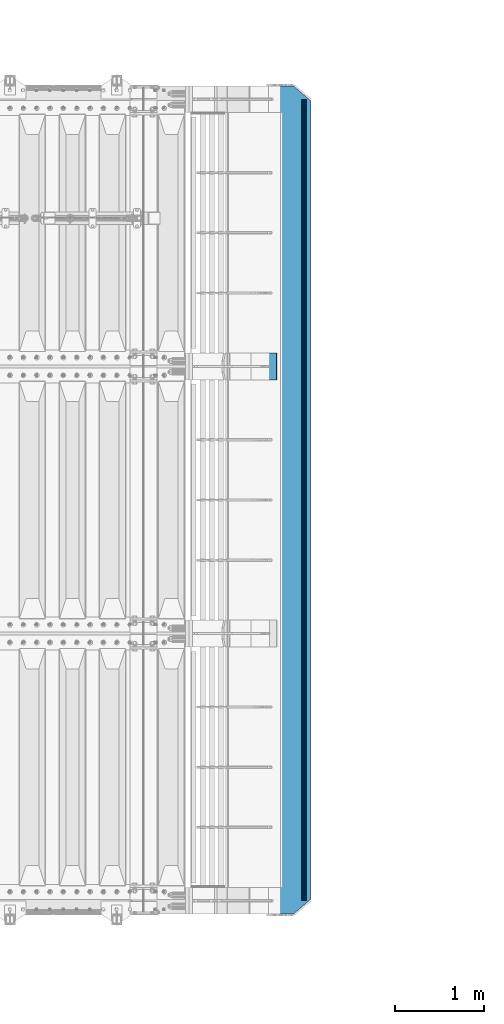
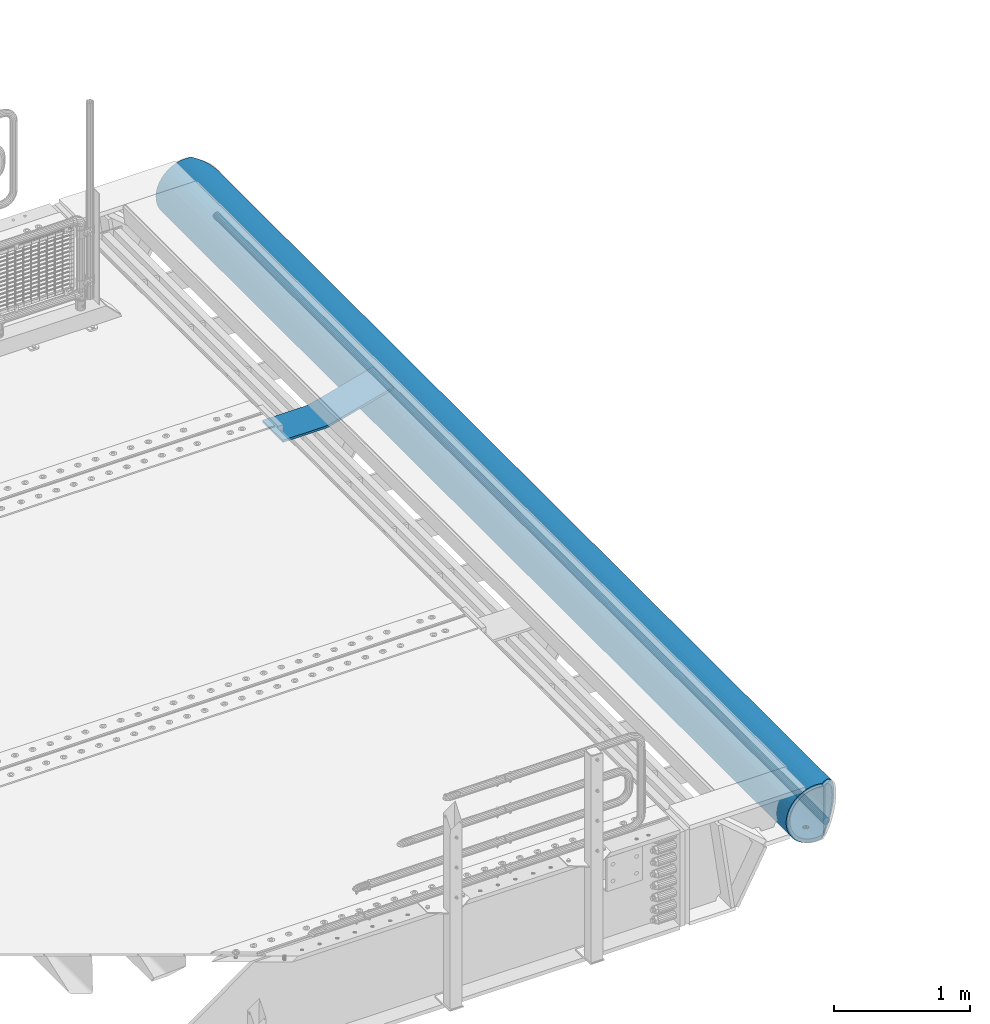
# One storey, part 144 of 270: 3 beams.
"""IFC2X3 building model written with IfcOpenShell, lengths in millimetres."""

from ifc_helpers import new_model, si_unit, frame, origin_with_axes, place, context, subcontext, project, spatial, faceted_brep, material, type_object, element, save


model = new_model("IFC2X3")

# Units and contexts
model_context = context("Model", 3, precision=1e-05, world=origin_with_axes())
body_context = subcontext(model_context, "Body", "Model", "MODEL_VIEW")
ifc_project = project(units=[si_unit("LENGTHUNIT", "METRE", prefix="MILLI"), si_unit("AREAUNIT", "SQUARE_METRE"), si_unit("VOLUMEUNIT", "CUBIC_METRE"), si_unit("MASSUNIT", "GRAM", prefix="KILO"), si_unit("TIMEUNIT", "SECOND"), si_unit("PLANEANGLEUNIT", "RADIAN"), si_unit("SOLIDANGLEUNIT", "STERADIAN"), si_unit("THERMODYNAMICTEMPERATUREUNIT", "DEGREE_CELSIUS"), si_unit("LUMINOUSINTENSITYUNIT", "LUMEN")], contexts=[model_context])

# Site, building, storey
site_placement = place(None, origin_with_axes())
site = spatial("IfcSite", under=ifc_project, at=site_placement, CompositionType="ELEMENT")
building_placement = place(site_placement, origin_with_axes())
building = spatial("IfcBuilding", under=site, at=building_placement, Name="Standard", CompositionType="ELEMENT")
storey_placement = place(building_placement, origin_with_axes())
storey = spatial("IfcBuildingStorey", under=building, at=storey_placement, Name="Undefined", CompositionType="ELEMENT", Elevation=0.0)

# Beams
ifc_material = material(Name="STEEL/S355N")
beam_type_1 = type_object("IfcBeamType", PredefinedType="NOTDEFINED")
beam_1_placement = place(storey_placement, frame((20469.9988298906, -18000.0, -169.999999999995), z_axis=(0.0, -1.0, 0.0), x_axis=(1.0, 0.0, 0.0)))
element("IfcBeam", 1, at=beam_1_placement, inside=storey, type_object=beam_type_1, material=ifc_material, context=body_context, shape_type="Brep", body=[
    faceted_brep([(0.0, 10.0, -150.0), (0.0, 10.0, 150.0), (356.495387467741, 10.0, 150.0), (356.495387467749, 9.99999999999901, -150.0), (0.0, -10.0, 150.0), (0.0, -10.0, -150.0), (356.495387467741, -10.0, -150.0), (356.495387467741, -10.0, 150.0), (382.770279632416, 11.7334369044542, 150.0), (382.770279632416, 11.7334369044542, -150.0), (385.397768848896, -8.09321940509935, -150.0), (385.397768848896, -8.09321940509935, 150.0), (413.799145684919, -2.40593045895554, -150.0), (413.799145684919, -2.40593045895554, 150.0), (408.589713119687, 16.9036995827646, 150.0), (408.589713119891, 16.9036995827009, -150.0), (939.000000000015, 160.0, 150.0), (939.000000000015, 160.0, -150.0), (944.209432565229, 140.69036995827, 150.0), (944.209432565229, 140.69036995827, -150.0)], [[[0, 1, 2, 3]], [[4, 5, 6, 7]], [[5, 4, 1, 0]], [[3, 2, 8, 9]], [[7, 6, 10, 11]], [[10, 12, 13, 11]], [[8, 14, 15, 9]], [[15, 14, 16, 17]], [[14, 8, 2, 1, 4, 7, 11, 13, 18, 16]], [[13, 12, 19, 18]], [[12, 10, 6, 5, 0, 3, 9, 15, 17, 19]], [[18, 19, 17, 16]]]),
])
beam_type_2 = type_object("IfcBeamType", PredefinedType="NOTDEFINED")
beam_2_placement = place(storey_placement, frame((21545.9988298906, -14850.0, -254.000000000001), z_axis=(0.0, 0.0, 1.0), x_axis=(0.0, -1.0, 0.0)))
element("IfcBeam", 2, at=beam_2_placement, inside=storey, type_object=beam_type_2, material=ifc_material, context=body_context, shape_type="Brep", body=[
    faceted_brep([(6132.32233047034, -17.6739734137809, -220.609028125962), (6132.32233047034, -17.6739734137809, -252.609028125962), (6126.90301168722, -9.56338969324497, -253.247344908112), (6126.90301168722, -9.56338969324497, -221.247344908112), (6140.43291419087, -23.0932921968997, -220.182518487904), (6140.43291419087, -23.0932921968997, -252.182518487904), (6150.0, -24.9963038841161, -220.032748220012), (6150.0, -24.9963038841161, -252.032748220013), (6159.56708580913, -23.0932921968997, -220.182518487904), (6159.56708580913, -23.0932921968997, -252.182518487904), (6167.67766952966, -17.6739734137809, -220.609028125962), (6167.67766952966, -17.6739734137809, -252.609028125962), (6173.09698831278, -9.56338969324497, -221.247344908112), (6173.09698831278, -9.56338969324497, -253.247344908112), (6175.0, 0.0, -222.0), (6175.0, 0.0, -254.0), (6173.09698831278, 9.57078192501285, -221.246763126855), (6173.09698831278, 9.57078192501285, -253.246763126855), (6167.67766952966, 17.6813656455488, -220.608446344705), (6167.67766952966, 17.6813656455488, -252.608446344705), (6159.56708580913, 23.1006844286676, -220.181936706647), (6159.56708580913, 23.1006844286676, -252.181936706647), (6150.0, 25.0036961158839, -220.032166438756), (6150.0, 25.0036961158839, -252.032166438756), (6140.43291419087, 23.1006844286676, -220.181936706647), (6140.43291419087, 23.1006844286676, -252.181936706647), (6132.32233047034, 17.6813656455488, -220.608446344705), (6132.32233047034, 17.6813656455488, -252.608446344705), (6126.90301168722, 9.57078192501285, -221.246763126855), (6126.90301168722, 9.57078192501285, -253.246763126855), (6125.0, 0.0, -222.0), (6125.0, 0.0, -254.0), (4632.32233047034, -17.6739734137773, -220.609028125962), (4632.32233047034, -17.6739734137773, -252.609028125962), (4626.90301168722, -9.56338969324133, -253.247344908112), (4626.90301168722, -9.56338969324133, -221.247344908113), (4640.43291419087, -23.0932921968961, -220.182518487904), (4640.43291419087, -23.0932921968961, -252.182518487904), (4650.0, -24.9963038841124, -220.032748220013), (4650.0, -24.9963038841124, -252.032748220013), (4659.56708580913, -23.0932921968961, -220.182518487904), (4659.56708580913, -23.0932921968961, -252.182518487904), (4667.67766952966, -17.6739734137773, -220.609028125962), (4667.67766952966, -17.6739734137773, -252.609028125962), (4673.09698831278, -9.56338969324133, -221.247344908113), (4673.09698831278, -9.56338969324133, -253.247344908112), (4675.0, 0.0, -222.0), (4675.0, 0.0, -254.0), (4673.09698831278, 9.57078192501649, -221.246763126855), (4673.09698831278, 9.57078192501649, -253.246763126855), (4667.67766952966, 17.6813656455524, -220.608446344705), (4667.67766952966, 17.6813656455524, -252.608446344705), (4659.56708580913, 23.1006844286712, -220.181936706647), (4659.56708580913, 23.1006844286712, -252.181936706646), (4650.0, 25.0036961158876, -220.032166438755), (4650.0, 25.0036961158876, -252.032166438755), (4640.43291419087, 23.1006844286712, -220.181936706647), (4640.43291419087, 23.1006844286712, -252.181936706646), (4632.32233047034, 17.6813656455524, -220.608446344705), (4632.32233047034, 17.6813656455524, -252.608446344705), (4626.90301168722, 9.57078192501649, -221.246763126855), (4626.90301168722, 9.57078192501649, -253.246763126855), (4625.0, 0.0, -222.0), (4625.0, 0.0, -254.0), (3132.32233047034, -17.6776695296612, -220.608737235334), (3132.32233047034, -17.6776695296612, -252.608737235334), (3126.90301168722, -9.56708580912527, -253.247054017484), (3126.90301168722, -9.56708580912527, -221.247054017484), (3140.43291419087, -23.09698831278, -220.182227597276), (3140.43291419087, -23.09698831278, -252.182227597276), (3150.0, -24.9999999999964, -220.032457329385), (3150.0, -24.9999999999964, -252.032457329385), (3159.56708580913, -23.09698831278, -220.182227597276), (3159.56708580913, -23.09698831278, -252.182227597276), (3167.67766952966, -17.6776695296612, -220.608737235334), (3167.67766952966, -17.6776695296612, -252.608737235334), (3173.09698831278, -9.56708580912527, -221.247054017484), (3173.09698831278, -9.56708580912527, -253.247054017484), (3175.0, 0.0, -222.0), (3175.0, 0.0, -254.0), (3173.09698831278, 9.56708580913255, -221.247054017483), (3173.09698831278, 9.56708580913255, -253.247054017483), (3167.67766952966, 17.6776695296685, -220.608737235333), (3167.67766952966, 17.6776695296685, -252.608737235333), (3159.56708580913, 23.0969883127873, -220.182227597275), (3159.56708580913, 23.0969883127873, -252.182227597275), (3150.0, 25.0000000000036, -220.032457329384), (3150.0, 25.0000000000036, -252.032457329383), (3140.43291419087, 23.0969883127873, -220.182227597275), (3140.43291419087, 23.0969883127873, -252.182227597275), (3132.32233047034, 17.6776695296685, -220.608737235333), (3132.32233047034, 17.6776695296685, -252.608737235333), (3126.90301168722, 9.56708580913255, -221.247054017483), (3126.90301168722, 9.56708580913255, -253.247054017483), (3125.0, 0.0, -222.0), (3125.0, 0.0, -254.0), (1632.32233047034, -17.6776695296612, -220.608737235334), (1632.32233047034, -17.6776695296612, -252.608737235334), (1626.90301168722, -9.56708580912527, -253.247054017484), (1626.90301168722, -9.56708580912527, -221.247054017484), (1640.43291419087, -23.09698831278, -220.182227597276), (1640.43291419087, -23.09698831278, -252.182227597275), (1650.0, -24.9999999999964, -220.032457329384), (1650.0, -24.9999999999964, -252.032457329384), (1659.56708580913, -23.09698831278, -220.182227597276), (1659.56708580913, -23.09698831278, -252.182227597275), (1667.67766952966, -17.6776695296612, -220.608737235334), (1667.67766952966, -17.6776695296612, -252.608737235334), (1673.09698831278, -9.56708580912527, -221.247054017484), (1673.09698831278, -9.56708580912527, -253.247054017484), (1675.0, 0.0, -222.0), (1675.0, 0.0, -254.0), (1673.09698831278, 9.56708580913255, -221.247054017483), (1673.09698831278, 9.56708580913255, -253.247054017483), (1667.67766952966, 17.6776695296685, -220.608737235333), (1667.67766952966, 17.6776695296685, -252.608737235333), (1659.56708580913, 23.0969883127873, -220.182227597275), (1659.56708580913, 23.0969883127873, -252.182227597275), (1650.0, 25.0000000000036, -220.032457329384), (1650.0, 25.0000000000036, -252.032457329384), (1640.43291419087, 23.0969883127873, -220.182227597275), (1640.43291419087, 23.0969883127873, -252.182227597275), (1632.32233047034, 17.6776695296685, -220.608737235333), (1632.32233047034, 17.6776695296685, -252.608737235333), (1626.90301168722, 9.56708580913255, -221.247054017483), (1626.90301168722, 9.56708580913255, -253.247054017483), (1625.0, 0.0, -222.0), (1625.0, 0.0, -254.0), (132.322330470337, -17.6776695296612, -220.608737235334), (132.322330470337, -17.6776695296612, -252.608737235334), (126.903011687218, -9.56708580912527, -253.247054017484), (126.903011687218, -9.56708580912527, -221.247054017484), (140.432914190873, -23.09698831278, -220.182227597276), (140.432914190873, -23.09698831278, -252.182227597276), (150.0, -24.9999999999964, -220.032457329385), (150.0, -24.9999999999964, -252.032457329384), (159.567085809127, -23.09698831278, -220.182227597276), (159.567085809127, -23.09698831278, -252.182227597276), (167.677669529663, -17.6776695296612, -220.608737235334), (167.677669529663, -17.6776695296612, -252.608737235334), (173.096988312782, -9.56708580912527, -221.247054017484), (173.096988312782, -9.56708580912527, -253.247054017484), (175.0, 0.0, -222.0), (175.0, 0.0, -254.0), (173.096988312782, 9.56708580913255, -221.247054017483), (173.096988312782, 9.56708580913255, -253.247054017484), (167.677669529663, 17.6776695296685, -220.608737235333), (167.677669529663, 17.6776695296685, -252.608737235333), (159.567085809127, 23.0969883127873, -220.182227597275), (159.567085809127, 23.0969883127873, -252.182227597275), (150.0, 25.0000000000036, -220.032457329384), (150.0, 25.0000000000036, -252.032457329384), (140.432914190873, 23.0969883127873, -220.182227597275), (140.432914190873, 23.0969883127873, -252.182227597275), (132.322330470337, 17.6776695296685, -220.608737235333), (132.322330470337, 17.6776695296685, -252.608737235333), (126.903011687218, 9.56708580913255, -221.247054017483), (126.903011687218, 9.56708580913255, -253.247054017484), (125.0, 0.0, -222.0), (125.0, 0.0, -254.0), (0.0, -34.7284512389306, -219.266811612121), (0.0, -68.6017727512371, -211.134546617524), (9300.0, -68.6017727512371, -211.134546617524), (9300.0, -34.7284512389306, -219.266811612121), (0.0, -100.785890942181, -197.803448369818), (9300.0, -100.785890942181, -197.803448369818), (0.0, -130.48832600893, -179.601772751238), (9300.0, -130.48832600893, -179.601772751238), (0.0, -156.977705423415, -156.977705423414), (9300.0, -156.977705423415, -156.977705423414), (0.0, -179.601772751237, -130.488326008929), (9300.0, -179.601772751237, -130.488326008929), (0.0, -197.803448369817, -100.785890942179), (9300.0, -197.803448369817, -100.785890942179), (0.0, -211.134546617523, -68.6017727512383), (9300.0, -211.134546617523, -68.6017727512383), (0.0, -219.26681161212, -34.7284512389313), (9300.0, -219.26681161212, -34.7284512389313), (0.0, -222.0, 0.0), (9300.0, -222.0, 0.0), (0.0, -219.26681161212, 34.7284512389313), (9300.0, -219.26681161212, 34.7284512389313), (0.0, -211.134546617523, 68.6017727512384), (9300.0, -211.134546617523, 68.6017727512384), (0.0, -197.803448369817, 100.785890942179), (9300.0, -197.803448369817, 100.785890942179), (0.0, -179.601772751237, 130.488326008929), (9300.0, -179.601772751237, 130.488326008929), (0.0, -156.977705423415, 156.977705423414), (9300.0, -156.977705423415, 156.977705423414), (0.0, -130.48832600893, 179.601772751238), (9300.0, -130.48832600893, 179.601772751238), (0.0, -100.785890942181, 197.803448369818), (9300.0, -100.785890942181, 197.803448369818), (0.0, -68.6017727512371, 211.134546617524), (9300.0, -68.6017727512371, 211.134546617524), (0.0, -34.7284512389306, 219.266811612121), (9300.0, -34.7284512389306, 219.266811612121), (0.0, 0.0, 222.0), (9300.0, 0.0, 222.0), (0.0, 34.7284512389306, 219.266811612121), (9300.0, 34.7284512389306, 219.266811612121), (9287.59163509755, 68.6017727512371, 211.134546617524), (9300.0, 54.0036961158876, 214.639234741095), (0.0, 54.0000000000036, 214.64012210001), (12.4115067427265, 68.6017727512371, 211.134546617524), (9260.23513515906, 100.785890942181, 197.803448369818), (39.7680069938215, 100.785890942181, 197.803448369818), (9234.98806583574, 130.48832600893, 179.601772751238), (65.0150766056395, 130.48832600893, 179.601772751238), (9212.47209376456, 156.977705423415, 156.977705423414), (87.5310489341173, 156.977705423415, 156.977705423414), (9193.24163690413, 179.601772751237, 130.488326008929), (106.761506014296, 179.601772751237, 130.488326008929), (9177.77021292458, 197.803448369817, 100.785890942179), (122.232930170645, 197.803448369817, 100.785890942179), (9166.438779631, 211.134546617523, 68.6017727512383), (133.56436359371, 211.134546617523, 68.6017727512383), (9159.52635451795, 219.26681161212, 34.7284512389312), (140.476788785751, 219.26681161212, 34.7284512389312), (9157.20314443274, 222.0, -2.8421709430404e-14), (142.799998897512, 222.0, -2.8421709430404e-14), (9159.52635451795, 219.26681161212, -34.7284512389313), (140.476788785751, 219.26681161212, -34.7284512389313), (9166.438779631, 211.134546617523, -68.6017727512383), (133.56436359371, 211.134546617523, -68.6017727512383), (9177.77021292458, 197.803448369817, -100.785890942179), (122.232930170645, 197.803448369817, -100.785890942179), (9193.24163690413, 179.601772751237, -130.488326008929), (106.761506014296, 179.601772751237, -130.488326008929), (9212.47209376456, 156.977705423415, -156.977705423414), (87.5310489341173, 156.977705423415, -156.977705423414), (9234.98806583574, 130.48832600893, -179.601772751238), (65.0150766056395, 130.48832600893, -179.601772751238), (9260.23513515906, 100.785890942181, -197.803448369818), (39.7680069938215, 100.785890942181, -197.803448369818), (9287.59163509755, 68.6017727512371, -211.134546617524), (12.4115067427265, 68.6017727512371, -211.134546617524), (0.0, 34.7284512389306, -219.266811612121), (9300.0, 34.7284512389306, -219.266811612121), (9300.0, 54.0036961158876, -214.639234741095), (0.0, 54.0000000000036, -214.64012210001), (9140.5700428831, 241.56835513897, -78.4903165712366), (9153.53483593071, 226.315657143845, -115.313586933845), (146.468307441461, 226.315657143845, -115.313586933845), (159.433100637221, 241.56835513897, -78.4903165712366), (9171.23637507848, 205.490316571235, -149.297454082288), (128.766768091404, 205.490316571235, -149.297454082288), (9193.23878968456, 179.605122421384, -179.605122421383), (106.764353233903, 179.605122421384, -179.605122421383), (9219.00030727952, 149.297454082287, -205.490316571237), (81.0028353445596, 149.297454082287, -205.490316571237), (9247.88659380258, 115.313586933844, -226.315657143845), (52.1165484914, 115.313586933844, -226.315657143845), (9279.18637301149, 78.4903165712349, -241.568355138969), (20.8167689248312, 78.4903165712349, -241.568355138969), (9300.0, 54.0036961158876, -247.447072591955), (9300.0, 39.7343541202172, -250.872838511165), (0.0, 39.7343541202172, -250.872838511165), (0.0, 54.0000000000036, -247.447959950869), (0.0, 0.0, -222.0), (0.0, 0.0, -254.0), (0.0, -39.7343541202172, -250.872838511165), (0.0, -78.4903165712349, -241.568355138969), (0.0, -115.313586933844, -226.315657143845), (0.0, -149.297454082287, -205.490316571237), (0.0, -179.605122421384, -179.605122421383), (0.0, -205.490316571235, -149.297454082288), (0.0, -226.315657143845, -115.313586933845), (0.0, -241.56835513897, -78.4903165712367), (0.0, -250.872838511164, -39.7343541202187), (0.0, -254.0, 0.0), (0.0, -250.872838511164, 39.7343541202187), (0.0, -241.56835513897, 78.4903165712366), (0.0, -226.315657143845, 115.313586933845), (0.0, -205.490316571235, 149.297454082288), (0.0, -179.605122421384, 179.605122421383), (0.0, -149.297454082287, 205.490316571237), (0.0, -115.313586933844, 226.315657143845), (0.0, -78.4903165712349, 241.568355138969), (0.0, -39.7343541202172, 250.872838511165), (0.0, 0.0, 254.0), (0.0, 39.7343541202172, 250.872838511165), (0.0, 54.0000000000036, 247.447959950869), (9300.0, -39.7343541202172, -250.872838511165), (9300.0, -78.4903165712349, -241.568355138969), (9300.0, -115.313586933844, -226.315657143845), (9300.0, -149.297454082287, -205.490316571237), (9300.0, -179.605122421384, -179.605122421383), (9300.0, -205.490316571235, -149.297454082288), (9300.0, -226.315657143845, -115.313586933845), (9300.0, -241.56835513897, -78.4903165712367), (9300.0, -250.872838511164, -39.7343541202187), (9300.0, -254.0, 0.0), (9300.0, -250.872838511164, 39.7343541202187), (9300.0, -241.56835513897, 78.4903165712366), (9300.0, -226.315657143845, 115.313586933845), (9300.0, -205.490316571235, 149.297454082288), (9300.0, -179.605122421384, 179.605122421383), (9300.0, -149.297454082287, 205.490316571237), (9300.0, -115.313586933844, 226.315657143845), (9300.0, -78.4903165712349, 241.568355138969), (9300.0, -39.7343541202172, 250.872838511165), (9300.0, 0.0, 254.0), (9300.0, 39.7343541202172, 250.872838511165), (9300.0, 54.0036961158876, 247.447072591955), (9279.18637301149, 78.4903165712349, 241.568355138969), (20.8167689248312, 78.4903165712349, 241.568355138969), (9247.88659380258, 115.313586933844, 226.315657143845), (52.1165484914, 115.313586933844, 226.315657143845), (9219.00030727952, 149.297454082287, 205.490316571237), (81.0028353445596, 149.297454082287, 205.490316571237), (9193.23878968456, 179.605122421384, 179.605122421383), (106.764353233903, 179.605122421384, 179.605122421383), (9171.23637507848, 205.490316571235, 149.297454082288), (128.766768091404, 205.490316571235, 149.297454082288), (9153.53483593071, 226.315657143845, 115.313586933845), (146.468307441461, 226.315657143845, 115.313586933845), (9140.5700428831, 241.56835513897, 78.4903165712367), (159.433100637221, 241.56835513897, 78.4903165712367), (9129.99999983257, 254.003700142406, 0.0), (9132.66123216817, 250.872838511164, -39.7343541202186), (167.341911442525, 250.872838511164, -39.7343541202186), (170.000001295226, 254.000003067897, 5.6843418860808e-14), (9132.66123216817, 250.872838511164, 39.7343541202187), (167.341911442525, 250.872838511164, 39.7343541202187), (9300.0, 0.0, -254.0), (9300.0, 0.0, -222.0), (7675.0, 0.0, -222.0), (7673.09698831278, -9.56338969324497, -221.247344908113), (7667.67766952966, -17.6739734137809, -220.609028125962), (7659.56708580913, -23.0932921968997, -220.182518487904), (7650.0, -24.9963038841161, -220.032748220013), (7640.43291419087, -23.0932921968997, -220.182518487904), (7632.32233047034, -17.6739734137809, -220.609028125962), (7626.90301168722, -9.56338969324497, -221.247344908113), (7625.0, 0.0, -222.0), (9175.0, 0.0, -222.0), (9173.09698831278, -9.56338969324861, -221.247344908112), (9167.67766952966, -17.6739734137846, -220.609028125962), (9159.56708580913, -23.0932921969033, -220.182518487904), (9150.0, -24.9963038841197, -220.032748220012), (9140.43291419087, -23.0932921969033, -220.182518487904), (9132.32233047034, -17.6739734137846, -220.609028125962), (9126.90301168722, -9.56338969324861, -221.247344908112), (9125.0, 0.0, -222.0), (9167.67766952966, 17.6813656455452, -220.608446344705), (9173.09698831278, 9.57078192500921, -221.246763126855), (7626.90301168722, 9.57078192501285, -221.246763126855), (7632.32233047034, 17.6813656455488, -220.608446344705), (7640.43291419087, 23.1006844286676, -220.181936706647), (7650.0, 25.0036961158839, -220.032166438756), (7659.56708580913, 23.1006844286676, -220.181936706647), (7667.67766952966, 17.6813656455488, -220.608446344705), (7673.09698831278, 9.57078192501285, -221.246763126855), (9126.90301168722, 9.57078192500921, -221.246763126855), (9132.32233047034, 17.6813656455452, -220.608446344705), (9140.43291419087, 23.100684428664, -220.181936706647), (9150.0, 25.0036961158803, -220.032166438756), (9159.56708580913, 23.100684428664, -220.181936706647), (7673.09698831278, 9.57078192501285, -253.246763126856), (7675.0, 0.0, -254.0), (7667.67766952966, 17.6813656455488, -252.608446344705), (7659.56708580913, 23.1006844286676, -252.181936706647), (7650.0, 25.0036961158839, -252.032166438756), (7640.43291419087, 23.1006844286676, -252.181936706647), (7632.32233047034, 17.6813656455488, -252.608446344705), (7626.90301168722, 9.57078192501285, -253.246763126856), (7625.0, 0.0, -254.0), (7626.90301168722, -9.56338969324497, -253.247344908111), (7632.32233047034, -17.6739734137809, -252.609028125961), (7640.43291419087, -23.0932921968997, -252.182518487903), (7650.0, -24.9963038841161, -252.032748220012), (7659.56708580913, -23.0932921968997, -252.182518487903), (7667.67766952966, -17.6739734137809, -252.609028125961), (7673.09698831278, -9.56338969324497, -253.247344908111), (9132.32233047034, -17.6739734137846, -252.609028125962), (9140.43291419087, -23.0932921969033, -252.182518487904), (9150.0, -24.9963038841197, -252.032748220013), (9159.56708580913, -23.0932921969033, -252.182518487904), (9167.67766952966, -17.6739734137846, -252.609028125962), (9173.09698831278, -9.56338969324861, -253.247344908112), (9175.0, 0.0, -254.0), (9125.0, 0.0, -254.0), (9126.90301168722, -9.56338969324861, -253.247344908112), (9132.32233047034, 17.6813656455452, -252.608446344706), (9126.90301168722, 9.57078192500921, -253.246763126856), (9173.09698831278, 9.57078192500921, -253.246763126856), (9167.67766952966, 17.6813656455452, -252.608446344706), (9159.56708580913, 23.100684428664, -252.181936706648), (9150.0, 25.0036961158803, -252.032166438757), (9140.43291419087, 23.100684428664, -252.181936706648)], [[[0, 1, 2, 3]], [[4, 5, 1, 0]], [[6, 7, 5, 4]], [[8, 9, 7, 6]], [[10, 11, 9, 8]], [[12, 13, 11, 10]], [[14, 15, 13, 12]], [[16, 17, 15, 14]], [[18, 19, 17, 16]], [[20, 21, 19, 18]], [[22, 23, 21, 20]], [[24, 25, 23, 22]], [[26, 27, 25, 24]], [[28, 29, 27, 26]], [[30, 31, 29, 28]], [[3, 2, 31, 30]], [[32, 33, 34, 35]], [[36, 37, 33, 32]], [[38, 39, 37, 36]], [[40, 41, 39, 38]], [[42, 43, 41, 40]], [[44, 45, 43, 42]], [[46, 47, 45, 44]], [[48, 49, 47, 46]], [[50, 51, 49, 48]], [[52, 53, 51, 50]], [[54, 55, 53, 52]], [[56, 57, 55, 54]], [[58, 59, 57, 56]], [[60, 61, 59, 58]], [[62, 63, 61, 60]], [[35, 34, 63, 62]], [[64, 65, 66, 67]], [[68, 69, 65, 64]], [[70, 71, 69, 68]], [[72, 73, 71, 70]], [[74, 75, 73, 72]], [[76, 77, 75, 74]], [[78, 79, 77, 76]], [[80, 81, 79, 78]], [[82, 83, 81, 80]], [[84, 85, 83, 82]], [[86, 87, 85, 84]], [[88, 89, 87, 86]], [[90, 91, 89, 88]], [[92, 93, 91, 90]], [[94, 95, 93, 92]], [[67, 66, 95, 94]], [[96, 97, 98, 99]], [[100, 101, 97, 96]], [[102, 103, 101, 100]], [[104, 105, 103, 102]], [[106, 107, 105, 104]], [[108, 109, 107, 106]], [[110, 111, 109, 108]], [[112, 113, 111, 110]], [[114, 115, 113, 112]], [[116, 117, 115, 114]], [[118, 119, 117, 116]], [[120, 121, 119, 118]], [[122, 123, 121, 120]], [[124, 125, 123, 122]], [[126, 127, 125, 124]], [[99, 98, 127, 126]], [[128, 129, 130, 131]], [[132, 133, 129, 128]], [[134, 135, 133, 132]], [[136, 137, 135, 134]], [[138, 139, 137, 136]], [[140, 141, 139, 138]], [[142, 143, 141, 140]], [[144, 145, 143, 142]], [[146, 147, 145, 144]], [[148, 149, 147, 146]], [[150, 151, 149, 148]], [[152, 153, 151, 150]], [[154, 155, 153, 152]], [[156, 157, 155, 154]], [[158, 159, 157, 156]], [[131, 130, 159, 158]], [[160, 161, 162, 163]], [[161, 164, 165, 162]], [[164, 166, 167, 165]], [[166, 168, 169, 167]], [[168, 170, 171, 169]], [[170, 172, 173, 171]], [[172, 174, 175, 173]], [[174, 176, 177, 175]], [[176, 178, 179, 177]], [[178, 180, 181, 179]], [[180, 182, 183, 181]], [[182, 184, 185, 183]], [[184, 186, 187, 185]], [[186, 188, 189, 187]], [[188, 190, 191, 189]], [[190, 192, 193, 191]], [[192, 194, 195, 193]], [[194, 196, 197, 195]], [[196, 198, 199, 197]], [[198, 200, 201, 199]], [[202, 203, 201, 200, 204, 205]], [[206, 202, 205, 207]], [[208, 206, 207, 209]], [[210, 208, 209, 211]], [[212, 210, 211, 213]], [[214, 212, 213, 215]], [[216, 214, 215, 217]], [[218, 216, 217, 219]], [[220, 218, 219, 221]], [[222, 220, 221, 223]], [[224, 222, 223, 225]], [[226, 224, 225, 227]], [[228, 226, 227, 229]], [[230, 228, 229, 231]], [[232, 230, 231, 233]], [[234, 232, 233, 235]], [[236, 234, 235, 237]], [[238, 239, 240, 236, 237, 241]], [[242, 243, 244, 245]], [[243, 246, 247, 244]], [[246, 248, 249, 247]], [[248, 250, 251, 249]], [[250, 252, 253, 251]], [[252, 254, 255, 253]], [[254, 256, 257, 258, 259, 255]], [[200, 198, 196, 194, 192, 190, 188, 186, 184, 182, 180, 178, 176, 174, 172, 170, 168, 166, 164, 161, 160, 260, 238, 241, 259, 258, 261, 262, 263, 264, 265, 266, 267, 268, 269, 270, 271, 272, 273, 274, 275, 276, 277, 278, 279, 280, 281, 282, 283, 204]], [[263, 262, 284, 285]], [[264, 263, 285, 286]], [[265, 264, 286, 287]], [[266, 265, 287, 288]], [[267, 266, 288, 289]], [[268, 267, 289, 290]], [[269, 268, 290, 291]], [[270, 269, 291, 292]], [[271, 270, 292, 293]], [[272, 271, 293, 294]], [[273, 272, 294, 295]], [[274, 273, 295, 296]], [[275, 274, 296, 297]], [[276, 275, 297, 298]], [[277, 276, 298, 299]], [[278, 277, 299, 300]], [[279, 278, 300, 301]], [[280, 279, 301, 302]], [[281, 280, 302, 303]], [[282, 281, 303, 304]], [[282, 304, 305, 306, 307, 283]], [[306, 308, 309, 307]], [[308, 310, 311, 309]], [[310, 312, 313, 311]], [[312, 314, 315, 313]], [[314, 316, 317, 315]], [[316, 318, 319, 317]], [[320, 321, 322, 323]], [[324, 320, 323, 325]], [[318, 324, 325, 319]], [[323, 322, 245, 244, 247, 249, 251, 253, 255, 259, 241, 237, 235, 233, 231, 229, 227, 225, 223, 221, 219, 217, 215, 213, 211, 209, 207, 205, 204, 283, 307, 309, 311, 313, 315, 317, 319, 325]], [[321, 242, 245, 322]], [[320, 324, 318, 316, 314, 312, 310, 308, 306, 305, 203, 202, 206, 208, 210, 212, 214, 216, 218, 220, 222, 224, 226, 228, 230, 232, 234, 236, 240, 256, 254, 252, 250, 248, 246, 243, 242, 321]], [[304, 303, 302, 301, 300, 299, 298, 297, 296, 295, 294, 293, 292, 291, 290, 289, 288, 287, 286, 285, 284, 326, 257, 256, 240, 239, 327, 163, 162, 165, 167, 169, 171, 173, 175, 177, 179, 181, 183, 185, 187, 189, 191, 193, 195, 197, 199, 201, 203, 305]], [[328, 329, 330, 331, 332, 333, 334, 335, 336, 14, 12, 10, 8, 6, 4, 0, 3, 30, 46, 44, 42, 40, 38, 36, 32, 35, 62, 78, 76, 74, 72, 70, 68, 64, 67, 94, 110, 108, 106, 104, 102, 100, 96, 99, 126, 142, 140, 138, 136, 134, 132, 128, 131, 158, 260, 160, 163, 327, 337, 338, 339, 340, 341, 342, 343, 344, 345]], [[346, 347, 337, 327, 239, 238, 260, 158, 156, 154, 152, 150, 148, 146, 144, 142, 126, 124, 122, 120, 118, 116, 114, 112, 110, 94, 92, 90, 88, 86, 84, 82, 80, 78, 62, 60, 58, 56, 54, 52, 50, 48, 46, 30, 28, 26, 24, 22, 20, 18, 16, 14, 336, 348, 349, 350, 351, 352, 353, 354, 328, 345, 355, 356, 357, 358, 359]], [[354, 360, 361, 328]], [[353, 362, 360, 354]], [[352, 363, 362, 353]], [[351, 364, 363, 352]], [[350, 365, 364, 351]], [[349, 366, 365, 350]], [[348, 367, 366, 349]], [[336, 368, 367, 348]], [[335, 369, 368, 336]], [[334, 370, 369, 335]], [[333, 371, 370, 334]], [[332, 372, 371, 333]], [[331, 373, 372, 332]], [[330, 374, 373, 331]], [[329, 375, 374, 330]], [[328, 361, 375, 329]], [[376, 377, 378, 379, 380, 381, 382, 326, 284, 262, 261, 159, 130, 129, 133, 135, 137, 139, 141, 143, 127, 98, 97, 101, 103, 105, 107, 109, 111, 95, 66, 65, 69, 71, 73, 75, 77, 79, 63, 34, 33, 37, 39, 41, 43, 45, 47, 31, 2, 1, 5, 7, 9, 11, 13, 15, 368, 369, 370, 371, 372, 373, 374, 375, 361, 383, 384]], [[385, 386, 383, 361, 360, 362, 363, 364, 365, 366, 367, 368, 15, 17, 19, 21, 23, 25, 27, 29, 31, 47, 49, 51, 53, 55, 57, 59, 61, 63, 79, 81, 83, 85, 87, 89, 91, 93, 95, 111, 113, 115, 117, 119, 121, 123, 125, 127, 143, 145, 147, 149, 151, 153, 155, 157, 159, 261, 258, 257, 326, 382, 387, 388, 389, 390, 391]], [[358, 390, 389, 359]], [[357, 391, 390, 358]], [[356, 385, 391, 357]], [[355, 386, 385, 356]], [[345, 383, 386, 355]], [[344, 384, 383, 345]], [[343, 376, 384, 344]], [[342, 377, 376, 343]], [[341, 378, 377, 342]], [[340, 379, 378, 341]], [[339, 380, 379, 340]], [[338, 381, 380, 339]], [[337, 382, 381, 338]], [[347, 387, 382, 337]], [[346, 388, 387, 347]], [[359, 389, 388, 346]]]),
])
beam_type_3 = type_object("IfcBeamType", Name="D60", PredefinedType="NOTDEFINED")
beam_3_placement = place(storey_placement, frame((21719.7525260065, -24000.0, -478.0), z_axis=(0.0, 0.0, 1.0), x_axis=(0.0, 1.0, 0.0)))
element("IfcBeam", 3, at=beam_3_placement, inside=storey, type_object=beam_type_3, material=ifc_material, ObjectType="D60", context=body_context, shape_type="Brep", body=[
    faceted_brep([(0.0, -30.0, 0.0), (0.0, -27.7163859753382, -11.4805029709527), (9000.00000000076, -27.7163859753382, -11.4805029709527), (9000.00000000076, -30.0, 0.0), (0.0, -21.2132034355964, -21.2132034355964), (9000.00000000076, -21.2132034355964, -21.2132034355964), (0.0, -11.4805029709532, -27.7163859753386), (9000.00000000076, -11.4805029709532, -27.7163859753386), (0.0, 0.0, -30.0), (9000.00000000076, 0.0, -30.0), (0.0, 11.4805029709532, -27.7163859753386), (9000.00000000076, 11.4805029709532, -27.7163859753386), (0.0, 21.2132034356, -21.2132034355964), (9000.00000000076, 21.2132034356, -21.2132034355964), (-3.63797880709171e-12, 27.7163859753382, -11.4805029709527), (9000.00000000076, 27.7163859753382, -11.4805029709527), (-3.63797880709171e-12, 30.0, 0.0), (9000.00000000076, 30.0, 0.0), (-3.63797880709171e-12, 27.7163859753382, 11.4805029709527), (9000.00000000076, 27.7163859753382, 11.4805029709527), (0.0, 21.2132034356, 21.2132034355964), (9000.00000000076, 21.2132034356, 21.2132034355964), (0.0, 11.4805029709532, 27.7163859753386), (9000.00000000076, 11.4805029709532, 27.7163859753386), (0.0, 0.0, 30.0), (9000.00000000076, 0.0, 30.0), (0.0, -11.4805029709532, 27.7163859753386), (9000.00000000076, -11.4805029709532, 27.7163859753386), (0.0, -21.2132034355964, 21.2132034355964), (9000.00000000076, -21.2132034355964, 21.2132034355964), (0.0, -27.7163859753382, 11.4805029709527), (9000.00000000076, -27.7163859753382, 11.4805029709527)], [[[0, 1, 2, 3]], [[1, 4, 5, 2]], [[4, 6, 7, 5]], [[6, 8, 9, 7]], [[8, 10, 11, 9]], [[10, 12, 13, 11]], [[12, 14, 15, 13]], [[14, 16, 17, 15]], [[16, 18, 19, 17]], [[18, 20, 21, 19]], [[20, 22, 23, 21]], [[22, 24, 25, 23]], [[24, 26, 27, 25]], [[26, 28, 29, 27]], [[28, 30, 31, 29]], [[30, 0, 3, 31]], [[5, 7, 9, 11, 13, 15, 17, 19, 21, 23, 25, 27, 29, 31, 3, 2]], [[30, 28, 26, 24, 22, 20, 18, 16, 14, 12, 10, 8, 6, 4, 1, 0]]]),
])

save(model, "model.ifc")
